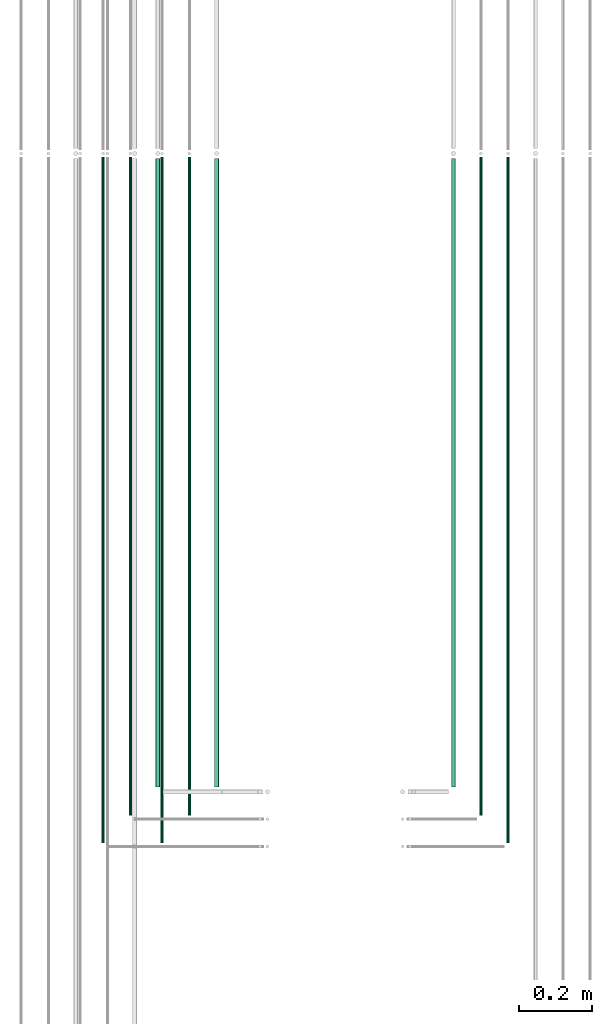
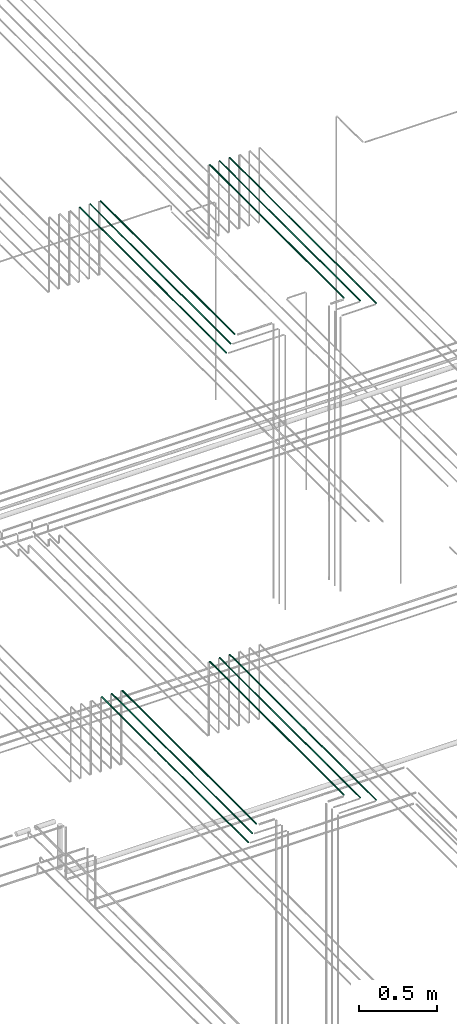
# One storey, part 14 of 331: 12 flow segments.
"""IFC2X3 building model written with IfcOpenShell, lengths in millimetres."""

from ifc_helpers import new_model, entity, si_unit, converted_unit, derived_unit, direction, frame, frame_2d, origin, origin_2d_with_axis, place, context, subcontext, project, spatial, circle, extrude, type_object, element, save


model = new_model("IFC2X3")

# Units and contexts
model_context = context("Model", 3, precision=0.01, world=origin(), true_north=direction((6.12303176911189e-17, 1.0)))
body_context = subcontext(model_context, "Body", "Model", "MODEL_VIEW")
ifc_project = project(units=[si_unit("LENGTHUNIT", "METRE", prefix="MILLI"), si_unit("AREAUNIT", "SQUARE_METRE"), si_unit("VOLUMEUNIT", "CUBIC_METRE"), converted_unit("PLANEANGLEUNIT", "DEGREE", entity("IfcRatioMeasure", 0.0174532925199433), si_unit("PLANEANGLEUNIT", "RADIAN"), dimensions=[0, 0, 0, 0, 0, 0, 0]), si_unit("MASSUNIT", "GRAM", prefix="KILO"), derived_unit("MASSDENSITYUNIT", [(si_unit("MASSUNIT", "GRAM", prefix="KILO"), 1), (si_unit("LENGTHUNIT", "METRE"), -3)]), derived_unit("MOMENTOFINERTIAUNIT", [(si_unit("LENGTHUNIT", "METRE"), 4)]), si_unit("TIMEUNIT", "SECOND"), si_unit("FREQUENCYUNIT", "HERTZ"), si_unit("THERMODYNAMICTEMPERATUREUNIT", "DEGREE_CELSIUS"), derived_unit("THERMALTRANSMITTANCEUNIT", [(si_unit("MASSUNIT", "GRAM", prefix="KILO"), 1), (si_unit("THERMODYNAMICTEMPERATUREUNIT", "KELVIN"), -1), (si_unit("TIMEUNIT", "SECOND"), -3)]), derived_unit("VOLUMETRICFLOWRATEUNIT", [(si_unit("LENGTHUNIT", "METRE"), 3), (si_unit("TIMEUNIT", "SECOND"), -1)]), derived_unit("MASSFLOWRATEUNIT", [(si_unit("MASSUNIT", "GRAM", prefix="KILO"), 1), (si_unit("TIMEUNIT", "SECOND"), -1)]), derived_unit("ROTATIONALFREQUENCYUNIT", [(si_unit("TIMEUNIT", "SECOND"), -1)]), si_unit("ELECTRICCURRENTUNIT", "AMPERE"), si_unit("ELECTRICVOLTAGEUNIT", "VOLT"), si_unit("POWERUNIT", "WATT"), si_unit("FORCEUNIT", "NEWTON", prefix="KILO"), si_unit("ILLUMINANCEUNIT", "LUX"), si_unit("LUMINOUSFLUXUNIT", "LUMEN"), si_unit("LUMINOUSINTENSITYUNIT", "CANDELA"), derived_unit("USERDEFINED", [(si_unit("MASSUNIT", "GRAM", prefix="KILO"), -1), (si_unit("LENGTHUNIT", "METRE"), -2), (si_unit("TIMEUNIT", "SECOND"), 3), (si_unit("LUMINOUSFLUXUNIT", "LUMEN"), 1)]), derived_unit("LINEARVELOCITYUNIT", [(si_unit("LENGTHUNIT", "METRE"), 1), (si_unit("TIMEUNIT", "SECOND"), -1)]), si_unit("PRESSUREUNIT", "PASCAL"), derived_unit("USERDEFINED", [(si_unit("LENGTHUNIT", "METRE"), -2), (si_unit("MASSUNIT", "GRAM", prefix="KILO"), 1), (si_unit("TIMEUNIT", "SECOND"), -2)]), derived_unit("LINEARFORCEUNIT", [(si_unit("MASSUNIT", "GRAM", prefix="KILO"), 1), (si_unit("LENGTHUNIT", "METRE"), 1), (si_unit("TIMEUNIT", "SECOND"), -2), (si_unit("LENGTHUNIT", "METRE"), -1)]), derived_unit("PLANARFORCEUNIT", [(si_unit("MASSUNIT", "GRAM", prefix="KILO"), 1), (si_unit("LENGTHUNIT", "METRE"), 1), (si_unit("TIMEUNIT", "SECOND"), -2), (si_unit("LENGTHUNIT", "METRE"), -2)])], contexts=[model_context])

# Site, building, storey
site_placement = place(None, frame((0.0, -0.00077364408347762, 0.0)))
site = spatial("IfcSite", under=ifc_project, at=site_placement, CompositionType="ELEMENT")
building_placement = place(site_placement, origin())
building = spatial("IfcBuilding", under=site, at=building_placement, CompositionType="ELEMENT")
storey_placement = place(building_placement, origin())
storey = spatial("IfcBuildingStorey", under=building, at=storey_placement, CompositionType="ELEMENT", Elevation=0.0)

# Flow segments
pipe_segment_type = type_object("IfcPipeSegmentType", PredefinedType="NOTDEFINED")
flow_segment_1_placement = place(storey_placement, frame((26088.5132663482, 3905.48876707916, 15142.4047277641)))
element("IfcFlowSegment", 1, at=flow_segment_1_placement, inside=storey, type_object=pipe_segment_type, context=body_context, shape_type="SweptSolid", body=[
    extrude(circle(Radius=6.0, at=origin_2d_with_axis()), frame((7.59527223591454, 0.0, 7.5952722359167), z_axis=(0.0, 1.0, 0.0), x_axis=(1.0, 0.0, 0.0)), (0.0, 0.0, 1.0), 1724.13179674825),
])
flow_segment_2_placement = place(storey_placement, frame((26165.5132663482, 3826.48876707975, 15144.4047277641)))
element("IfcFlowSegment", 2, at=flow_segment_2_placement, inside=storey, type_object=pipe_segment_type, context=body_context, shape_type="SweptSolid", body=[
    extrude(circle(Radius=4.0, at=origin_2d_with_axis()), frame((5.59527223591499, 0.0, 5.59527223591499), z_axis=(0.0, 1.0, 0.0), x_axis=(1.0, 0.0, 0.0)), (0.0, 0.0, 1.0), 1807.13179674766),
])
flow_segment_3_placement = place(storey_placement, frame((26240.5132663482, 3751.48876707881, 15144.4047277641)))
element("IfcFlowSegment", 3, at=flow_segment_3_placement, inside=storey, type_object=pipe_segment_type, context=body_context, shape_type="SweptSolid", body=[
    extrude(circle(Radius=4.0, at=origin_2d_with_axis()), frame((5.59527223591499, 0.0, 5.59527223591499), z_axis=(0.0, 1.0, 0.0), x_axis=(1.0, 0.0, 0.0)), (0.0, 0.0, 1.0), 1882.1317967486),
])
flow_segment_4_placement = place(storey_placement, frame((25438.5132663482, 3905.4887670787, 15142.4047277641)))
element("IfcFlowSegment", 4, at=flow_segment_4_placement, inside=storey, type_object=pipe_segment_type, context=body_context, shape_type="SweptSolid", body=[
    extrude(circle(Radius=6.0, at=frame_2d((0.0, 2.16573425859679e-12), x_axis=(1.0, 0.0))), frame((7.59527223591454, 0.0, 7.59527223591887), z_axis=(0.0, 1.0, 0.0), x_axis=(1.0, 0.0, 0.0)), (0.0, 0.0, 1.0), 1724.13179674871),
])
flow_segment_5_placement = place(storey_placement, frame((25365.5132663482, 3826.48876707975, 15144.4047277641)))
element("IfcFlowSegment", 5, at=flow_segment_5_placement, inside=storey, type_object=pipe_segment_type, context=body_context, shape_type="SweptSolid", body=[
    extrude(circle(Radius=4.0, at=origin_2d_with_axis()), frame((5.59527223591499, 0.0, 5.59527223591499), z_axis=(0.0, 1.0, 0.0), x_axis=(1.0, 0.0, 0.0)), (0.0, 0.0, 1.0), 1807.13179674766),
])
flow_segment_6_placement = place(storey_placement, frame((25290.5132663482, 3751.48876707885, 15144.4047277641)))
element("IfcFlowSegment", 6, at=flow_segment_6_placement, inside=storey, type_object=pipe_segment_type, context=body_context, shape_type="SweptSolid", body=[
    extrude(circle(Radius=4.0, at=origin_2d_with_axis()), frame((5.59527223591499, 0.0, 5.59527223591499), z_axis=(0.0, 1.0, 0.0), x_axis=(1.0, 0.0, 0.0)), (0.0, 0.0, 1.0), 1882.13179674856),
])
flow_segment_7_placement = place(storey_placement, frame((26088.733655358, 3905.4887670797, 19042.4047277641)))
element("IfcFlowSegment", 7, at=flow_segment_7_placement, inside=storey, type_object=pipe_segment_type, context=body_context, shape_type="SweptSolid", body=[
    extrude(circle(Radius=6.0, at=origin_2d_with_axis()), frame((7.59527223591454, 0.0, 7.5952722359167), z_axis=(0.0, 1.0, 0.0), x_axis=(1.0, 0.0, 0.0)), (0.0, 0.0, 1.0), 1724.13179674766),
])
flow_segment_8_placement = place(storey_placement, frame((26165.733655358, 3826.48876707969, 19044.4047277641)))
element("IfcFlowSegment", 8, at=flow_segment_8_placement, inside=storey, type_object=pipe_segment_type, context=body_context, shape_type="SweptSolid", body=[
    extrude(circle(Radius=4.0, at=origin_2d_with_axis()), frame((5.59527223591499, 0.0, 5.59527223591499), z_axis=(0.0, 1.0, 0.0), x_axis=(1.0, 0.0, 0.0)), (0.0, 0.0, 1.0), 1807.13179674766),
])
flow_segment_9_placement = place(storey_placement, frame((26240.733655358, 3751.48876707969, 19044.4047277641)))
element("IfcFlowSegment", 9, at=flow_segment_9_placement, inside=storey, type_object=pipe_segment_type, context=body_context, shape_type="SweptSolid", body=[
    extrude(circle(Radius=4.0, at=origin_2d_with_axis()), frame((5.59527223591499, 0.0, 5.59527223591499), z_axis=(0.0, 1.0, 0.0), x_axis=(1.0, 0.0, 0.0)), (0.0, 0.0, 1.0), 1882.13179674766),
])
flow_segment_10_placement = place(storey_placement, frame((25276.7436346567, 3905.48876707975, 19042.4047277641)))
element("IfcFlowSegment", 10, at=flow_segment_10_placement, inside=storey, type_object=pipe_segment_type, context=body_context, shape_type="SweptSolid", body=[
    extrude(circle(Radius=6.0, at=origin_2d_with_axis()), frame((7.59527223608779, 0.0, 7.5952722359167), z_axis=(0.0, 1.0, 0.0), x_axis=(1.0, 0.0, 0.0)), (0.0, 0.0, 1.0), 1724.13179674761),
])
flow_segment_11_placement = place(storey_placement, frame((25203.7436346567, 3826.48876707976, 19044.4047277641)))
element("IfcFlowSegment", 11, at=flow_segment_11_placement, inside=storey, type_object=pipe_segment_type, context=body_context, shape_type="SweptSolid", body=[
    extrude(circle(Radius=4.0, at=origin_2d_with_axis()), frame((5.5952722361229, 0.0, 5.59527223591499), z_axis=(0.0, 1.0, 0.0), x_axis=(1.0, 0.0, 0.0)), (0.0, 0.0, 1.0), 1807.13210329044),
])
flow_segment_12_placement = place(storey_placement, frame((25128.7436346567, 3751.48876707975, 19044.4047277641)))
element("IfcFlowSegment", 12, at=flow_segment_12_placement, inside=storey, type_object=pipe_segment_type, context=body_context, shape_type="SweptSolid", body=[
    extrude(circle(Radius=4.0, at=origin_2d_with_axis()), frame((5.5952722360536, 0.0, 5.59527223591499), z_axis=(0.0, 1.0, 0.0), x_axis=(1.0, 0.0, 0.0)), (0.0, 0.0, 1.0), 1882.13179674759),
])

save(model, "model.ifc")
